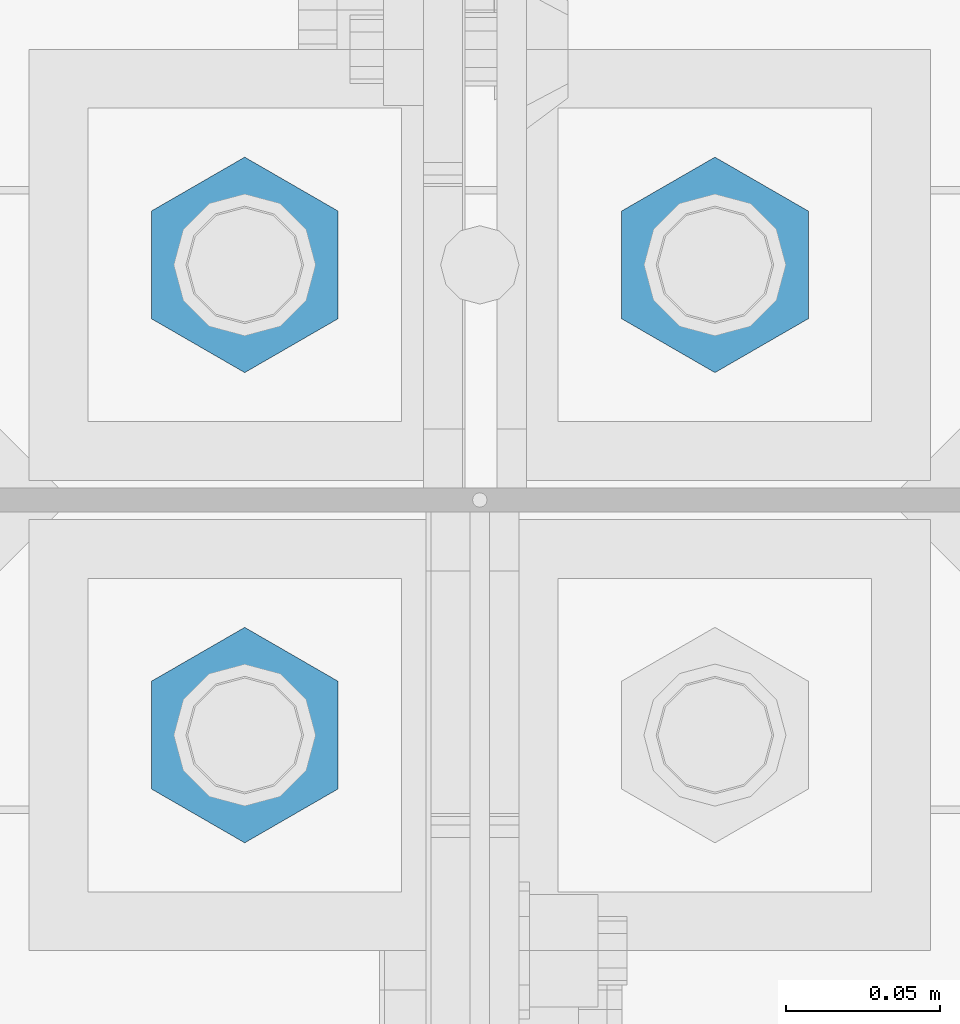
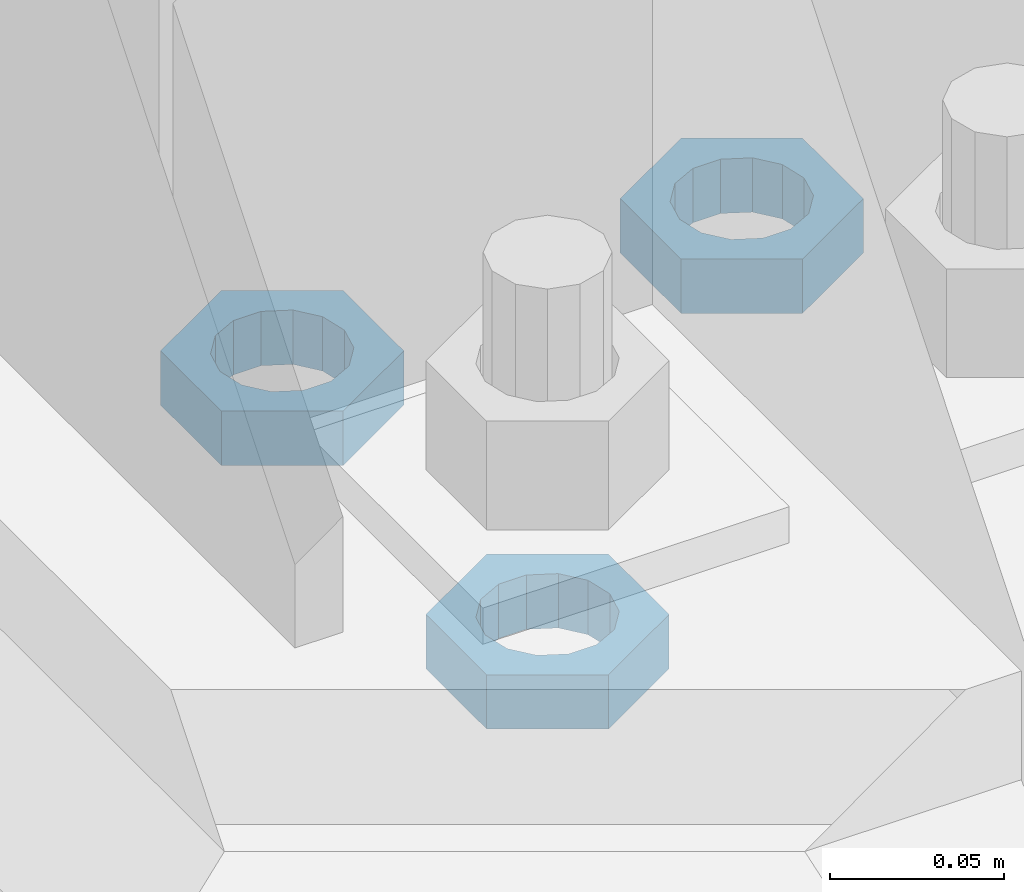
# One storey, part 2845 of 3843: 3 beams, 1 element without a shape of its own.
"""IFC2X3 building model written with IfcOpenShell, lengths in millimetres."""

from ifc_helpers import new_model, si_unit, frame, origin_with_axes, place, context, subcontext, project, spatial, faceted_brep, material, type_object, element, aggregate, save


model = new_model("IFC2X3")

# Units and contexts
model_context = context("Model", 3, precision=1e-05, world=origin_with_axes())
body_context = subcontext(model_context, "Body", "Model", "MODEL_VIEW")
ifc_project = project(units=[si_unit("LENGTHUNIT", "METRE", prefix="MILLI"), si_unit("AREAUNIT", "SQUARE_METRE"), si_unit("VOLUMEUNIT", "CUBIC_METRE"), si_unit("MASSUNIT", "GRAM", prefix="KILO"), si_unit("TIMEUNIT", "SECOND"), si_unit("PLANEANGLEUNIT", "RADIAN"), si_unit("SOLIDANGLEUNIT", "STERADIAN"), si_unit("THERMODYNAMICTEMPERATUREUNIT", "DEGREE_CELSIUS"), si_unit("LUMINOUSINTENSITYUNIT", "LUMEN")], contexts=[model_context])

# Site, building, storey
site_placement = place(None, origin_with_axes())
site = spatial("IfcSite", under=ifc_project, at=site_placement, CompositionType="ELEMENT")
building_placement = place(site_placement, origin_with_axes())
building = spatial("IfcBuilding", under=site, at=building_placement, Name="Undefined", CompositionType="ELEMENT")
storey_placement = place(building_placement, origin_with_axes())
storey = spatial("IfcBuildingStorey", under=building, at=storey_placement, Name="Undefined", CompositionType="ELEMENT", Elevation=0.0)

# Assembly, beams
assembly_placement = place(storey_placement, origin_with_axes())
assembly = element("IfcElementAssembly", 1, at=assembly_placement, inside=storey, Name="TEMPLATE", AssemblyPlace="NOTDEFINED", PredefinedType="RIGID_FRAME")
ifc_material = material(Name="STEEL/A572-50")
beam_type = type_object("IfcBeamType", Name="1-1/2_HALF_NUT", PredefinedType="NOTDEFINED")
beam_1_placement = place(assembly_placement, frame((77089.0, 28790.9, 30060.9), z_axis=(-1.0, 0.0, 0.0), x_axis=(0.0, 0.0, -1.0)))
beam_1 = element("IfcBeam", 2, at=beam_1_placement, type_object=beam_type, material=ifc_material, Name="NUT", ObjectType="1-1/2_HALF_NUT", context=body_context, shape_type="Brep", body=[
    faceted_brep([(0.0, -34.9199981689453, 0.0), (0.0, -17.4599990844727, -30.25), (19.0500000000029, -17.4599990844727, -30.25), (19.0500000000029, -34.9199981689453, 0.0), (0.0, 17.4599990844727, -30.25), (19.0500000000029, 17.4599990844727, -30.25), (0.0, 34.9199981689453, 0.0), (19.0500000000029, 34.9199981689453, 0.0), (0.0, 17.4599990844727, 30.25), (19.0500000000029, 17.4599990844727, 30.25), (0.0, -17.4599990844727, 30.25), (19.0500000000029, -17.4599990844727, 30.25), (0.0, 0.0, 20.6399993896484), (0.0, 8.9553601105581, 18.5959968835959), (19.0500000000029, 8.95536011056538, 18.5959968835959), (19.0500000000029, 0.0, 20.6399993896484), (0.0, 16.1370013209525, 12.8688291298167), (19.0500000000029, 16.1370013209489, 12.8688291298167), (0.0, 20.1225115123816, 4.59283194104501), (19.0500000000029, 20.1225115123852, 4.59283194104501), (0.0, 20.1225115123816, -4.59283194104501), (19.0500000000029, 20.1225115123852, -4.59283194104501), (0.0, 16.1370013209525, -12.8688291298167), (19.0500000000029, 16.1370013209489, -12.8688291298167), (0.0, 8.9553601105581, -18.5959968835959), (19.0500000000029, 8.95536011056538, -18.5959968835959), (0.0, 0.0, -20.6399993896484), (19.0500000000029, 0.0, -20.6399993896484), (0.0, -8.9553601105581, -18.5959968835959), (19.0500000000029, -8.95536011056538, -18.5959968835959), (0.0, -16.1370013209525, -12.8688291298167), (19.0500000000029, -16.1370013209489, -12.8688291298167), (0.0, -20.1225115123816, -4.59283194104501), (19.0500000000029, -20.1225115123852, -4.59283194104501), (0.0, -20.1225115123816, 4.59283194104501), (19.0500000000029, -20.1225115123852, 4.59283194104501), (0.0, -16.1370013209525, 12.8688291298167), (19.0500000000029, -16.1370013209489, 12.8688291298167), (0.0, -8.9553601105581, 18.5959968835959), (19.0500000000029, -8.95536011056538, 18.5959968835959)], [[[0, 1, 2, 3]], [[1, 4, 5, 2]], [[4, 6, 7, 5]], [[6, 8, 9, 7]], [[8, 10, 11, 9]], [[10, 0, 3, 11]], [[12, 13, 14, 15]], [[13, 16, 17, 14]], [[16, 18, 19, 17]], [[18, 20, 21, 19]], [[20, 22, 23, 21]], [[22, 24, 25, 23]], [[24, 26, 27, 25]], [[26, 28, 29, 27]], [[28, 30, 31, 29]], [[30, 32, 33, 31]], [[32, 34, 35, 33]], [[34, 36, 37, 35]], [[36, 38, 39, 37]], [[38, 12, 15, 39]], [[5, 7, 9, 11, 3, 2], [17, 19, 21, 23, 25, 27, 29, 31, 33, 35, 37, 39, 15, 14]], [[10, 8, 6, 4, 1, 0], [38, 36, 34, 32, 30, 28, 26, 24, 22, 20, 18, 16, 13, 12]]]),
])
beam_2_placement = place(assembly_placement, frame((76936.6, 28790.9, 30060.9), z_axis=(-1.0, 0.0, 0.0), x_axis=(0.0, 0.0, -1.0)))
beam_2 = element("IfcBeam", 3, at=beam_2_placement, type_object=beam_type, material=ifc_material, Name="NUT", ObjectType="1-1/2_HALF_NUT", context=body_context, shape_type="Brep", body=[
    faceted_brep([(0.0, -34.9199981689453, 0.0), (0.0, -17.4599990844727, -30.25), (19.0500000000029, -17.4599990844727, -30.25), (19.0500000000029, -34.9199981689453, 0.0), (0.0, 17.4599990844727, -30.25), (19.0500000000029, 17.4599990844727, -30.25), (0.0, 34.9199981689453, 0.0), (19.0500000000029, 34.9199981689453, 0.0), (0.0, 17.4599990844727, 30.25), (19.0500000000029, 17.4599990844727, 30.25), (0.0, -17.4599990844727, 30.25), (19.0500000000029, -17.4599990844727, 30.25), (0.0, 0.0, 20.6399993896484), (0.0, 8.9553601105581, 18.5959968835959), (19.0500000000029, 8.95536011056538, 18.5959968835959), (19.0500000000029, 0.0, 20.6399993896484), (0.0, 16.1370013209525, 12.8688291298167), (19.0500000000029, 16.1370013209489, 12.8688291298167), (0.0, 20.1225115123816, 4.59283194104501), (19.0500000000029, 20.1225115123852, 4.59283194104501), (0.0, 20.1225115123816, -4.59283194104501), (19.0500000000029, 20.1225115123852, -4.59283194104501), (0.0, 16.1370013209525, -12.8688291298167), (19.0500000000029, 16.1370013209489, -12.8688291298167), (0.0, 8.9553601105581, -18.5959968835959), (19.0500000000029, 8.95536011056538, -18.5959968835959), (0.0, 0.0, -20.6399993896484), (19.0500000000029, 0.0, -20.6399993896484), (0.0, -8.9553601105581, -18.5959968835959), (19.0500000000029, -8.95536011056538, -18.5959968835959), (0.0, -16.1370013209525, -12.8688291298167), (19.0500000000029, -16.1370013209489, -12.8688291298167), (0.0, -20.1225115123816, -4.59283194104501), (19.0500000000029, -20.1225115123852, -4.59283194104501), (0.0, -20.1225115123816, 4.59283194104501), (19.0500000000029, -20.1225115123852, 4.59283194104501), (0.0, -16.1370013209525, 12.8688291298167), (19.0500000000029, -16.1370013209489, 12.8688291298167), (0.0, -8.9553601105581, 18.5959968835959), (19.0500000000029, -8.95536011056538, 18.5959968835959)], [[[0, 1, 2, 3]], [[1, 4, 5, 2]], [[4, 6, 7, 5]], [[6, 8, 9, 7]], [[8, 10, 11, 9]], [[10, 0, 3, 11]], [[12, 13, 14, 15]], [[13, 16, 17, 14]], [[16, 18, 19, 17]], [[18, 20, 21, 19]], [[20, 22, 23, 21]], [[22, 24, 25, 23]], [[24, 26, 27, 25]], [[26, 28, 29, 27]], [[28, 30, 31, 29]], [[30, 32, 33, 31]], [[32, 34, 35, 33]], [[34, 36, 37, 35]], [[36, 38, 39, 37]], [[38, 12, 15, 39]], [[5, 7, 9, 11, 3, 2], [17, 19, 21, 23, 25, 27, 29, 31, 33, 35, 37, 39, 15, 14]], [[10, 8, 6, 4, 1, 0], [38, 36, 34, 32, 30, 28, 26, 24, 22, 20, 18, 16, 13, 12]]]),
])
beam_3_placement = place(assembly_placement, frame((76936.6, 28638.5, 30060.9), z_axis=(1.0, 0.0, 0.0), x_axis=(0.0, 0.0, -1.0)))
beam_3 = element("IfcBeam", 4, at=beam_3_placement, type_object=beam_type, material=ifc_material, Name="NUT", ObjectType="1-1/2_HALF_NUT", context=body_context, shape_type="Brep", body=[
    faceted_brep([(0.0, -34.9199981689453, 0.0), (0.0, -17.4599990844727, -30.25), (19.0500000000029, -17.4599990844727, -30.25), (19.0500000000029, -34.9199981689453, 0.0), (0.0, 17.4599990844727, -30.25), (19.0500000000029, 17.4599990844727, -30.25), (0.0, 34.9199981689453, 0.0), (19.0500000000029, 34.9199981689453, 0.0), (0.0, 17.4599990844727, 30.25), (19.0500000000029, 17.4599990844727, 30.25), (0.0, -17.4599990844727, 30.25), (19.0500000000029, -17.4599990844727, 30.25), (0.0, 0.0, 20.6399993896484), (0.0, 8.9553601105581, 18.5959968835959), (19.0500000000029, 8.95536011056538, 18.5959968835959), (19.0500000000029, 0.0, 20.6399993896484), (0.0, 16.1370013209525, 12.8688291298167), (19.0500000000029, 16.1370013209489, 12.8688291298167), (0.0, 20.1225115123816, 4.59283194104501), (19.0500000000029, 20.1225115123852, 4.59283194104501), (0.0, 20.1225115123816, -4.59283194104501), (19.0500000000029, 20.1225115123852, -4.59283194104501), (0.0, 16.1370013209525, -12.8688291298167), (19.0500000000029, 16.1370013209489, -12.8688291298167), (0.0, 8.9553601105581, -18.5959968835959), (19.0500000000029, 8.95536011056538, -18.5959968835959), (0.0, 0.0, -20.6399993896484), (19.0500000000029, 0.0, -20.6399993896484), (0.0, -8.9553601105581, -18.5959968835959), (19.0500000000029, -8.95536011056538, -18.5959968835959), (0.0, -16.1370013209525, -12.8688291298167), (19.0500000000029, -16.1370013209489, -12.8688291298167), (0.0, -20.1225115123816, -4.59283194104501), (19.0500000000029, -20.1225115123852, -4.59283194104501), (0.0, -20.1225115123816, 4.59283194104501), (19.0500000000029, -20.1225115123852, 4.59283194104501), (0.0, -16.1370013209525, 12.8688291298167), (19.0500000000029, -16.1370013209489, 12.8688291298167), (0.0, -8.9553601105581, 18.5959968835959), (19.0500000000029, -8.95536011056538, 18.5959968835959)], [[[0, 1, 2, 3]], [[1, 4, 5, 2]], [[4, 6, 7, 5]], [[6, 8, 9, 7]], [[8, 10, 11, 9]], [[10, 0, 3, 11]], [[12, 13, 14, 15]], [[13, 16, 17, 14]], [[16, 18, 19, 17]], [[18, 20, 21, 19]], [[20, 22, 23, 21]], [[22, 24, 25, 23]], [[24, 26, 27, 25]], [[26, 28, 29, 27]], [[28, 30, 31, 29]], [[30, 32, 33, 31]], [[32, 34, 35, 33]], [[34, 36, 37, 35]], [[36, 38, 39, 37]], [[38, 12, 15, 39]], [[5, 7, 9, 11, 3, 2], [17, 19, 21, 23, 25, 27, 29, 31, 33, 35, 37, 39, 15, 14]], [[10, 8, 6, 4, 1, 0], [38, 36, 34, 32, 30, 28, 26, 24, 22, 20, 18, 16, 13, 12]]]),
])
aggregate(assembly, [beam_1, beam_2, beam_3])

save(model, "model.ifc")
